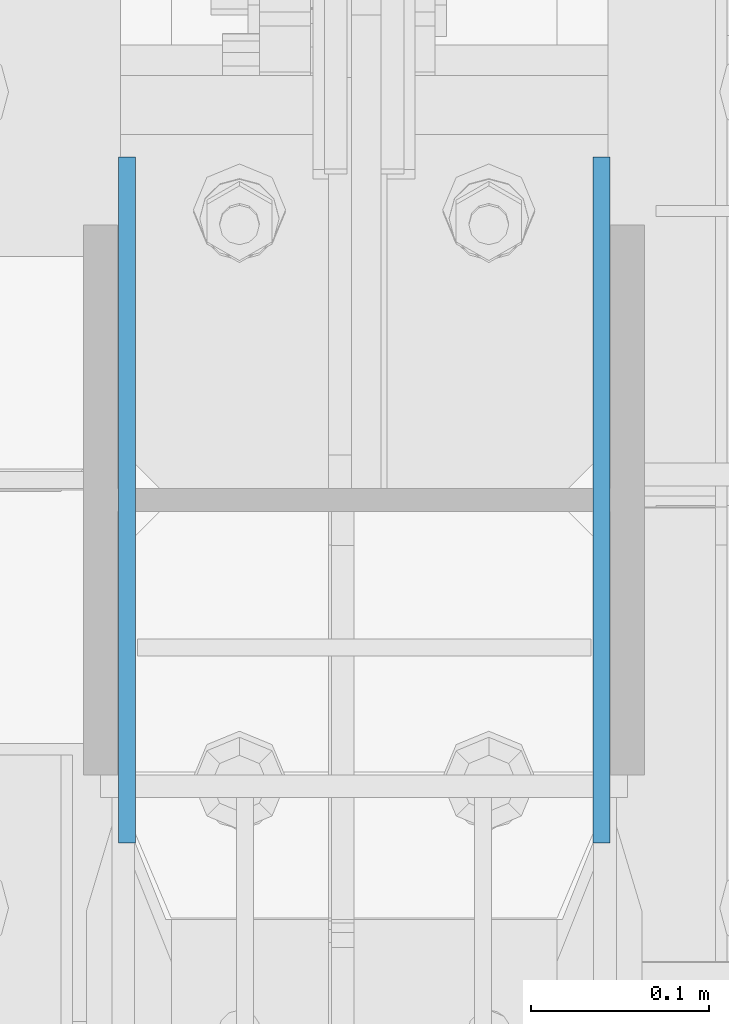
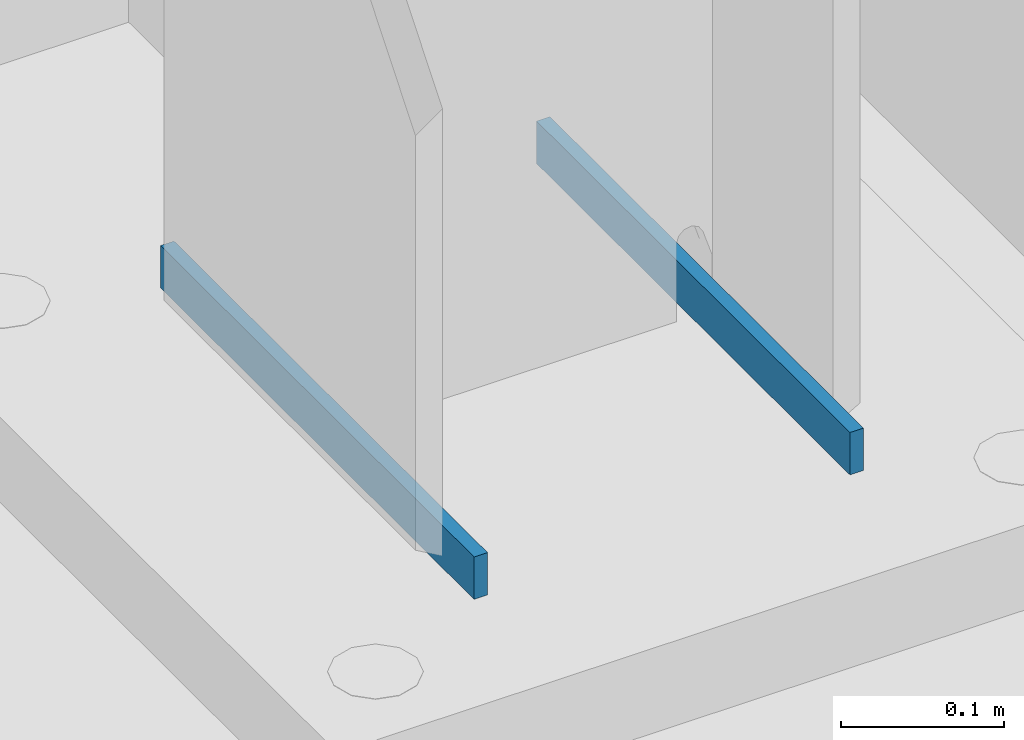
# One storey, part 466 of 1179: 2 columns, 1 element without a shape of its own.
"""IFC2X3 building model written with IfcOpenShell, lengths in millimetres."""

from ifc_helpers import new_model, si_unit, frame, origin_with_axes, place, context, subcontext, project, spatial, faceted_brep, material, type_object, element, aggregate, save


model = new_model("IFC2X3")

# Units and contexts
model_context = context("Model", 3, precision=1e-05, world=origin_with_axes())
body_context = subcontext(model_context, "Body", "Model", "MODEL_VIEW")
ifc_project = project(units=[si_unit("LENGTHUNIT", "METRE", prefix="MILLI"), si_unit("AREAUNIT", "SQUARE_METRE"), si_unit("VOLUMEUNIT", "CUBIC_METRE"), si_unit("MASSUNIT", "GRAM", prefix="KILO"), si_unit("TIMEUNIT", "SECOND"), si_unit("PLANEANGLEUNIT", "RADIAN"), si_unit("SOLIDANGLEUNIT", "STERADIAN"), si_unit("THERMODYNAMICTEMPERATUREUNIT", "DEGREE_CELSIUS"), si_unit("LUMINOUSINTENSITYUNIT", "LUMEN")], contexts=[model_context])

# Site, building, storey
site_placement = place(None, origin_with_axes())
site = spatial("IfcSite", under=ifc_project, at=site_placement, CompositionType="ELEMENT")
building_placement = place(site_placement, origin_with_axes())
building = spatial("IfcBuilding", under=site, at=building_placement, Name="Undefined", CompositionType="ELEMENT")
storey_placement = place(building_placement, origin_with_axes())
storey = spatial("IfcBuildingStorey", under=building, at=storey_placement, Name="Undefined", CompositionType="ELEMENT", Elevation=0.0)

# Assembly, columns
assembly_placement = place(storey_placement, origin_with_axes())
assembly = element("IfcElementAssembly", 1, at=assembly_placement, inside=storey, Name="COLUMN", AssemblyPlace="NOTDEFINED", PredefinedType="RIGID_FRAME")
ifc_material = material(Name="STEEL/A572-GR.50")
column_type = type_object("IfcColumnType", PredefinedType="NOTDEFINED")
column_1_placement = place(assembly_placement, frame((24440.753, 27051.0, -215.9), z_axis=(0.0, -1.0, 0.0), x_axis=(0.0, 0.0, 1.0)))
column_1 = element("IfcColumn", 2, at=column_1_placement, type_object=column_type, material=ifc_material, Name="PLATE", context=body_context, shape_type="Brep", body=[
    faceted_brep([(0.0, 4.76249999999982, -192.087500000001), (0.0, 4.76249999999982, 192.0875), (31.75, 4.76249999999982, 192.0875), (31.75, 4.76249999999982, -192.087500000001), (0.0, -4.76249999999982, 192.0875), (31.75, -4.76249999999982, 192.0875), (0.0, -4.76249999999982, -192.087500000001), (31.75, -4.76249999999982, -192.087500000001)], [[[0, 1, 2, 3]], [[1, 4, 5, 2]], [[4, 6, 7, 5]], [[6, 0, 3, 7]], [[5, 7, 3, 2]], [[6, 4, 1, 0]]]),
])
column_2_placement = place(assembly_placement, frame((24174.846875, 27051.0, -215.9), z_axis=(0.0, -1.0, 0.0), x_axis=(0.0, 0.0, 1.0)))
column_2 = element("IfcColumn", 3, at=column_2_placement, type_object=column_type, material=ifc_material, Name="PLATE", context=body_context, shape_type="Brep", body=[
    faceted_brep([(0.0, 4.76249999999982, -192.087500000001), (0.0, 4.76249999999982, 192.0875), (31.75, 4.76249999999982, 192.0875), (31.75, 4.76249999999982, -192.087500000001), (0.0, -4.76249999999982, 192.0875), (31.75, -4.76249999999982, 192.0875), (0.0, -4.76249999999982, -192.087500000001), (31.75, -4.76249999999982, -192.087500000001)], [[[0, 1, 2, 3]], [[1, 4, 5, 2]], [[4, 6, 7, 5]], [[6, 0, 3, 7]], [[5, 7, 3, 2]], [[6, 4, 1, 0]]]),
])
aggregate(assembly, [column_1, column_2])

save(model, "model.ifc")
